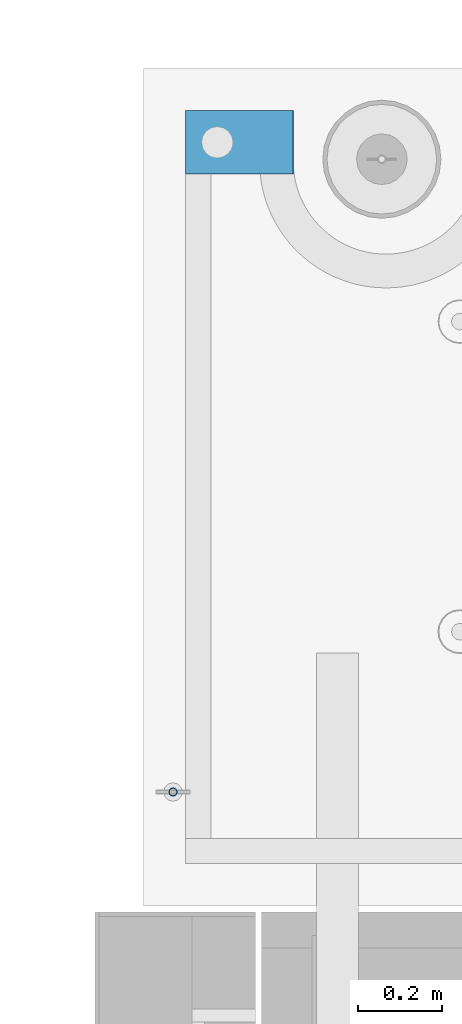
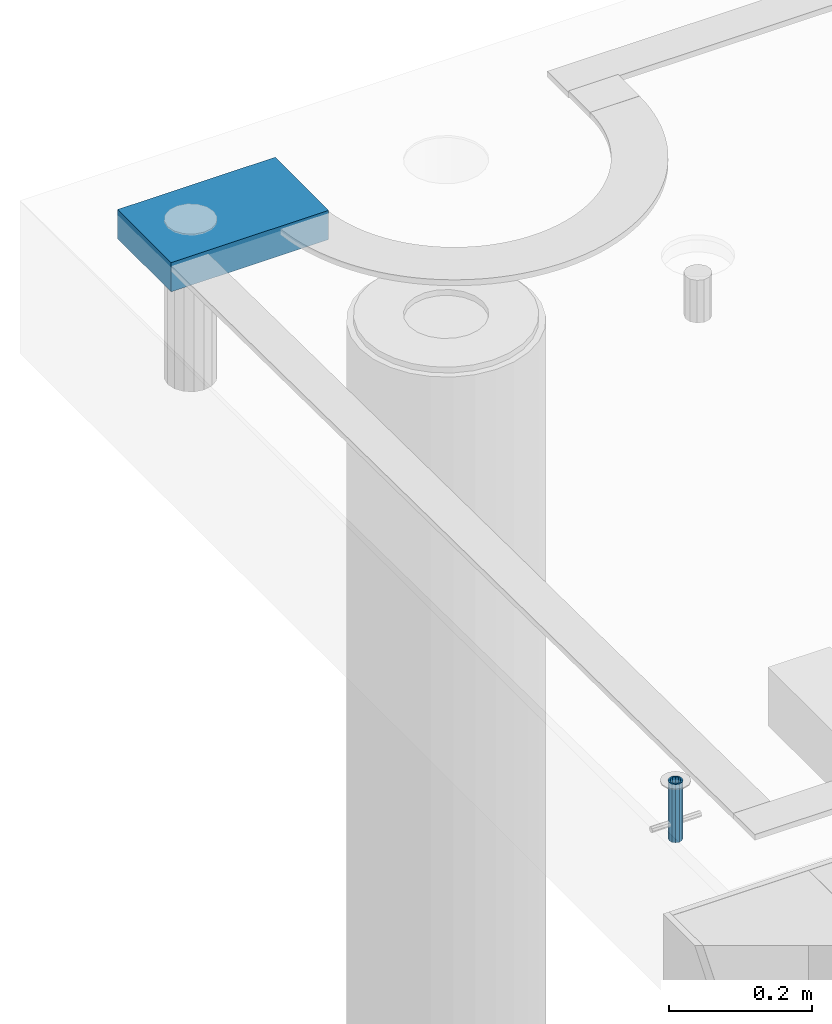
# One storey, part 149 of 341: 2 beams, 2 elements without a shape of their own.
"""IFC2X3 building model written with IfcOpenShell, lengths in millimetres."""

from ifc_helpers import new_model, si_unit, frame, origin_with_axes, place, context, subcontext, project, spatial, faceted_brep, material, type_object, element, aggregate, save


model = new_model("IFC2X3")

# Units and contexts
model_context = context("Model", 3, precision=1e-05, world=origin_with_axes())
body_context = subcontext(model_context, "Body", "Model", "MODEL_VIEW")
ifc_project = project(units=[si_unit("LENGTHUNIT", "METRE", prefix="MILLI"), si_unit("AREAUNIT", "SQUARE_METRE"), si_unit("VOLUMEUNIT", "CUBIC_METRE"), si_unit("MASSUNIT", "GRAM", prefix="KILO"), si_unit("TIMEUNIT", "SECOND"), si_unit("PLANEANGLEUNIT", "RADIAN"), si_unit("SOLIDANGLEUNIT", "STERADIAN"), si_unit("THERMODYNAMICTEMPERATUREUNIT", "DEGREE_CELSIUS"), si_unit("LUMINOUSINTENSITYUNIT", "LUMEN")], contexts=[model_context])

# Site, building, storey
site_placement = place(None, origin_with_axes())
site = spatial("IfcSite", under=ifc_project, at=site_placement, CompositionType="ELEMENT")
building_placement = place(site_placement, origin_with_axes())
building = spatial("IfcBuilding", under=site, at=building_placement, CompositionType="ELEMENT")
storey_placement = place(building_placement, origin_with_axes())
storey = spatial("IfcBuildingStorey", under=building, at=storey_placement, Name="5", CompositionType="ELEMENT", Elevation=0.0)

# Assemblies, beams
assembly_1_placement = place(storey_placement, origin_with_axes())
assembly_1 = element("IfcElementAssembly", 1, at=assembly_1_placement, inside=storey, AssemblyPlace="NOTDEFINED", PredefinedType="REINFORCEMENT_UNIT")
ifc_material_1 = material(Name="CONCRETE/Concrete_Undefined")
beam_type_1 = type_object("IfcBeamType", PredefinedType="NOTDEFINED")
beam_1_placement = place(assembly_1_placement, frame((7834.97852488622, 22709.9981419457, 96691.8130006467), z_axis=(-0.000811736999627788, 6.99999872856177e-09, 0.999999670541467), x_axis=(0.99999967050638, -8.37699998998561e-06, 0.000811736999618736)))
beam_1 = element("IfcBeam", 2, at=beam_1_placement, type_object=beam_type_1, material=ifc_material_1, context=body_context, shape_type="Brep", body=[
    faceted_brep([(0.0, 75.0, -25.0), (1.81898940354586e-12, 75.0, 25.0), (254.995831308013, 74.9999999999964, 24.9999999999709), (254.995831308012, 74.9999999999964, -25.0000000000146), (1.81898940354586e-12, -75.0000000000009, 25.0), (254.995831308014, -75.0000000000036, 24.9999999999854), (0.0, -75.0, -25.0), (254.995831308011, -75.0000000000036, -25.0000000000146)], [[[0, 1, 2, 3]], [[1, 4, 5, 2]], [[4, 6, 7, 5]], [[6, 0, 3, 7]], [[5, 7, 3, 2]], [[6, 4, 1, 0]]]),
])
assembly_2_placement = place(assembly_1_placement, origin_with_axes())
assembly_2 = element("IfcElementAssembly", 3, at=assembly_2_placement, Name="Steel Assembly", AssemblyPlace="NOTDEFINED", PredefinedType="RIGID_FRAME")
aggregate(assembly_1, [assembly_2, beam_1])
ifc_material_2 = material(Name="STEEL/1.4301")
beam_type_2 = type_object("IfcBeamType", PredefinedType="NOTDEFINED")
beam_2_placement = place(assembly_2_placement, frame((7804.99906039055, 21170.0168887753, 96730.9999983246), z_axis=(-1.43919999976435e-05, -0.999999999896435, 0.0), x_axis=(0.0, 0.0, -1.0)))
beam_2 = element("IfcBeam", 4, at=beam_2_placement, type_object=beam_type_2, material=ifc_material_2, context=body_context, shape_type="Brep", body=[
    faceted_brep([(0.0, -8.0, 0.0), (0.0, -6.92820323027263, 4.0), (100.000000000029, -6.92820323027263, 4.0), (100.000000000029, -7.99999999999636, 0.0), (0.0, -4.0, 6.92820323027627), (100.000000000029, -4.0, 6.92820323027536), (0.0, 0.0, 8.0), (100.000000000029, 3.63797880709171e-12, 8.0), (0.0, 4.0, 6.92820323027627), (100.000000000029, 4.0, 6.92820323027536), (0.0, 6.92820323027263, 4.0), (100.000000000029, 6.92820323027627, 3.99999999999909), (0.0, 8.0, 0.0), (100.000000000029, 8.0, 0.0), (0.0, 6.92820323027263, -4.0), (100.000000000029, 6.92820323027627, -4.00000000000091), (0.0, 4.0, -6.92820323027627), (100.000000000029, 4.00000000000364, -6.92820323027536), (0.0, 0.0, -8.0), (100.000000000029, 3.63797880709171e-12, -8.00000000000091), (0.0, -4.0, -6.92820323027627), (100.000000000029, -3.99999999999636, -6.92820323027627), (0.0, -6.92820323027263, -4.0), (100.000000000029, -6.92820323027263, -4.0), (0.0, -10.4999999999927, -1.45519152283669e-11), (0.0, -9.09326673972828, -5.25000000001455), (100.000000000262, -9.09326673972828, -5.25000000001455), (100.000000000262, -10.4999999999927, -1.45519152283669e-11), (0.0, -5.24999999998545, -9.09326673974283), (100.000000000262, -5.24999999998545, -9.09326673974283), (0.0, 7.27595761418343e-12, -10.5), (100.000000000262, 7.27595761418343e-12, -10.5), (0.0, 5.25000000001455, -9.09326673975738), (100.000000000262, 5.25000000001455, -9.09326673975738), (0.0, 9.09326673975011, -5.25000000001455), (100.000000000262, 9.09326673975011, -5.25000000001455), (0.0, 10.5000000000073, -1.45519152283669e-11), (100.000000000262, 10.5000000000073, -1.45519152283669e-11), (0.0, 9.09326673975011, 5.25), (100.000000000262, 9.09326673975011, 5.25), (0.0, 5.25000000000728, 9.09326673972828), (100.000000000262, 5.25000000000728, 9.09326673972828), (0.0, 1.45519152283669e-11, 10.4999999999854), (100.000000000262, 1.45519152283669e-11, 10.4999999999854), (0.0, -5.24999999999272, 9.09326673972828), (100.000000000262, -5.24999999999272, 9.09326673972828), (0.0, -9.09326673972828, 5.24999999998545), (100.000000000262, -9.09326673972828, 5.24999999998545)], [[[0, 1, 2, 3]], [[1, 4, 5, 2]], [[4, 6, 7, 5]], [[6, 8, 9, 7]], [[8, 10, 11, 9]], [[10, 12, 13, 11]], [[12, 14, 15, 13]], [[14, 16, 17, 15]], [[16, 18, 19, 17]], [[18, 20, 21, 19]], [[20, 22, 23, 21]], [[22, 0, 3, 23]], [[24, 25, 26, 27]], [[25, 28, 29, 26]], [[28, 30, 31, 29]], [[30, 32, 33, 31]], [[32, 34, 35, 33]], [[34, 36, 37, 35]], [[36, 38, 39, 37]], [[38, 40, 41, 39]], [[40, 42, 43, 41]], [[42, 44, 45, 43]], [[44, 46, 47, 45]], [[46, 24, 27, 47]], [[29, 31, 33, 35, 37, 39, 41, 43, 45, 47, 27, 26], [5, 7, 9, 11, 13, 15, 17, 19, 21, 23, 3, 2]], [[46, 44, 42, 40, 38, 36, 34, 32, 30, 28, 25, 24], [22, 20, 18, 16, 14, 12, 10, 8, 6, 4, 1, 0]]]),
])
aggregate(assembly_2, [beam_2])

save(model, "model.ifc")
